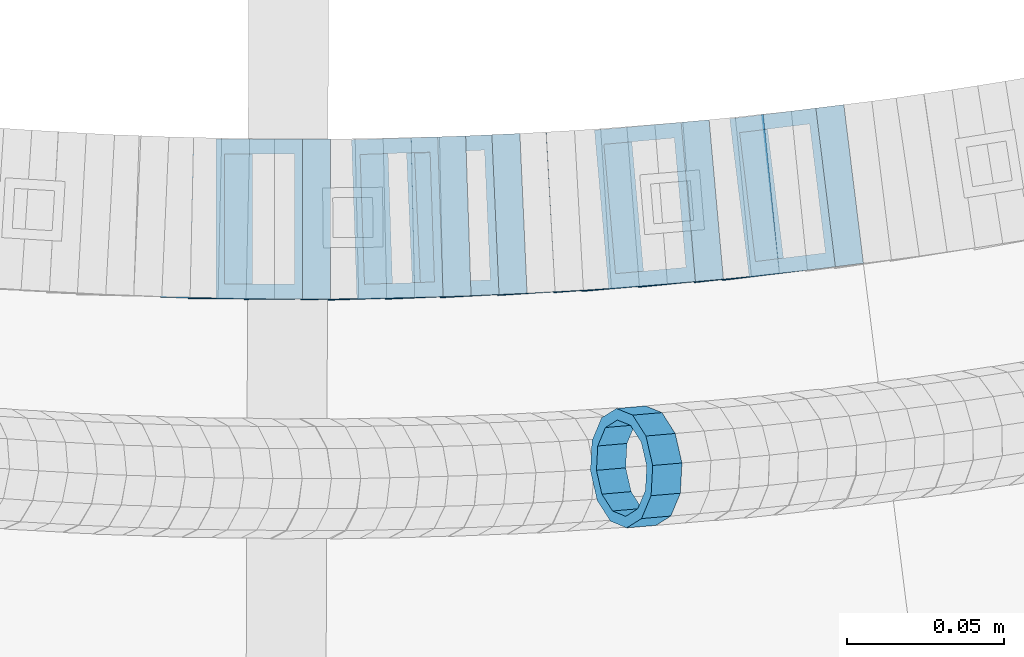
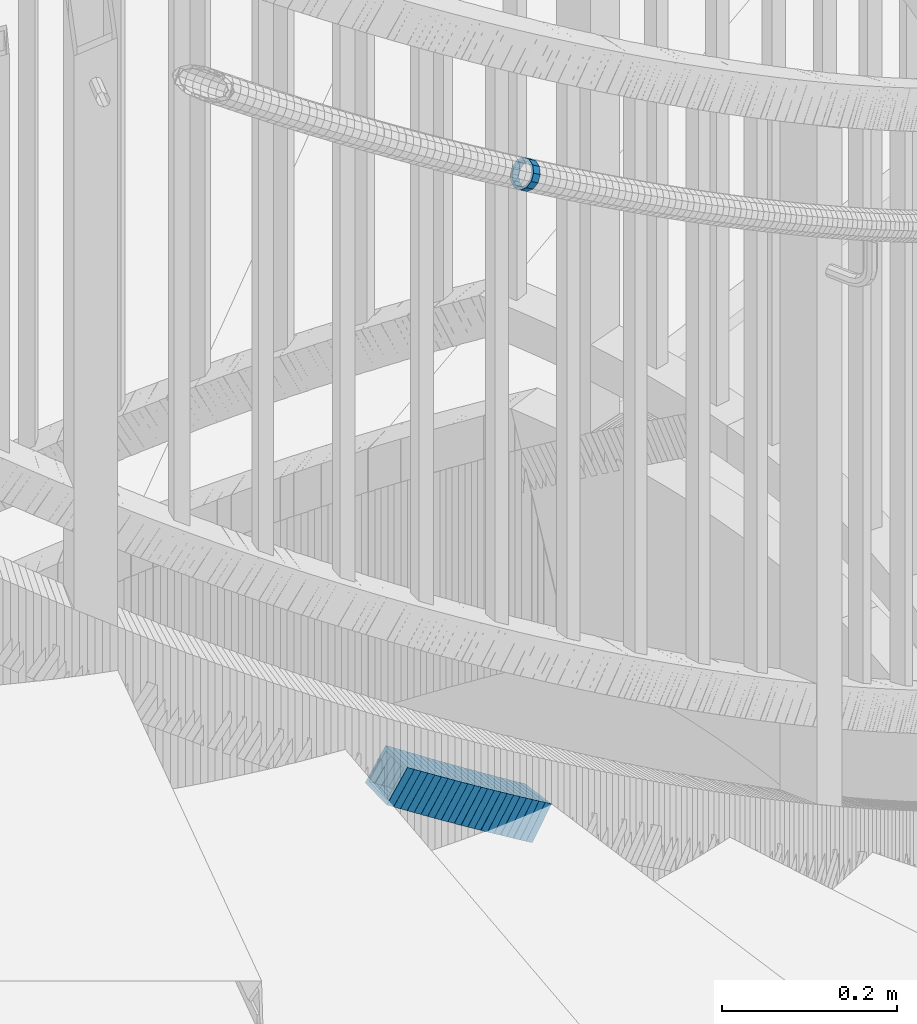
# One storey, part 710 of 975: 23 members.
"""IFC2X3 building model written with IfcOpenShell, lengths in millimetres."""

import ifcopenshell
import ifcopenshell.guid

model = None  # the IFC model being written
_history = None  # IfcOwnerHistory: only IFC2X3 demands one
_inside = {}  # id of a spatial element -> (the spatial element, [elements in it])
_under = {}  # id of a project, library or spatial element -> (it, [spatial elements below it])
_declared = {}  # id of a project -> (the project, [libraries it declares])
_typed = {}  # id of a type object -> (the type object, [elements of that type])
_made_of = {}  # id of a material, layer set ... -> (it, [elements and type objects made of it])


def new_model(schema):
    """Start an empty IFC model of exactly this schema.

    Asked for "IFC4X3", IfcOpenShell would pick the latest addendum, in which some entities
    have other attributes; the version numbers below select the first issue.
    IFC2X3 requires an IfcOwnerHistory on every rooted entity: one is made here for all.
    """
    global model, _history
    if schema == "IFC4X3":
        model = ifcopenshell.file(schema_version=(4, 3, 0, 0))
    else:
        model = ifcopenshell.file(schema=schema)
    _inside.clear()
    _under.clear()
    _declared.clear()
    _typed.clear()
    _made_of.clear()
    _history = None
    if model.schema == "IFC2X3":
        org = make("IfcOrganization", Name="unknown")
        user = make(
            "IfcPersonAndOrganization",
            ThePerson=make("IfcPerson", FamilyName="unknown"),
            TheOrganization=org,
        )
        app = make(
            "IfcApplication",
            ApplicationDeveloper=org,
            Version="unknown",
            ApplicationFullName="unknown",
            ApplicationIdentifier="unknown",
        )
        _history = make(
            "IfcOwnerHistory",
            OwningUser=user,
            OwningApplication=app,
            ChangeAction="ADDED",
            CreationDate=0,
        )
    return model


def make(cls, **values):
    """One entity of the class cls with the attributes given. An attribute that is None is left unset."""
    return model.create_entity(
        cls, **{name: value for name, value in values.items() if value is not None}
    )


def rooted(cls, **values):
    """An entity with a GlobalId (a new one), such as an element, a storey or a relation."""
    return make(cls, GlobalId=ifcopenshell.guid.new(), OwnerHistory=_history, **values)


def si_unit(unit_type, name, prefix=None):
    """IfcSIUnit, for example si_unit("LENGTHUNIT", "METRE", prefix="MILLI")."""
    return make("IfcSIUnit", UnitType=unit_type, Prefix=prefix, Name=name)


def assignment(units):
    """IfcUnitAssignment: the units of a project."""
    return None if units is None else make("IfcUnitAssignment", Units=units)


def point(xyz):
    """IfcCartesianPoint."""
    return None if xyz is None else make("IfcCartesianPoint", Coordinates=xyz)


def direction(xyz):
    """IfcDirection."""
    return None if xyz is None else make("IfcDirection", DirectionRatios=xyz)


def frame(location, z_axis=None, x_axis=None):
    """IfcAxis2Placement3D, a coordinate frame: its origin and axes. An axis left out is left unset."""
    return make(
        "IfcAxis2Placement3D",
        Location=point(location),
        Axis=direction(z_axis),
        RefDirection=direction(x_axis),
    )


def origin_with_axes():
    """The frame at (0, 0, 0) with the z axis (0, 0, 1) and the x axis (1, 0, 0) written out."""
    return frame((0.0, 0.0, 0.0), z_axis=(0.0, 0.0, 1.0), x_axis=(1.0, 0.0, 0.0))


def place(relative_to, where):
    """IfcLocalPlacement: puts the frame where relative to a parent placement (None: the world)."""
    return make(
        "IfcLocalPlacement", PlacementRelTo=relative_to, RelativePlacement=where
    )


def context(
    kind, dimensions, precision=None, world=None, true_north=None, identifier=None
):
    """IfcGeometricRepresentationContext, for example the 3D "Model" context."""
    return make(
        "IfcGeometricRepresentationContext",
        ContextIdentifier=identifier,
        ContextType=kind,
        CoordinateSpaceDimension=dimensions,
        Precision=precision,
        WorldCoordinateSystem=world,
        TrueNorth=true_north,
    )


def subcontext(parent, identifier, kind, view, scale=None):
    """IfcGeometricRepresentationSubContext, for example "Body" below "Model"."""
    return make(
        "IfcGeometricRepresentationSubContext",
        ContextIdentifier=identifier,
        ContextType=kind,
        ParentContext=parent,
        TargetScale=scale,
        TargetView=view,
    )


def project(units=None, contexts=None):
    """IfcProject with its units and contexts."""
    return rooted(
        "IfcProject",
        Name="project",
        RepresentationContexts=contexts,
        UnitsInContext=assignment(units),
    )


def spatial(cls, under=None, at=None, **own):
    """A site, building, storey or space (cls), placed at a placement, below another one or the project."""
    s = rooted(cls, ObjectPlacement=at, **own)
    if under is not None:
        _under.setdefault(under.id(), (under, []))[1].append(s)
    return s


def faces_of(points, faces, orient=None, outer=None):
    """IfcFace entities. A face is a list of loops; a loop is a list of indices into points, from 0.

    orient and outer hold one flag for each loop. By default every Orientation is true, the
    first loop of a face is its IfcFaceOuterBound and the others are IfcFaceBound.
    """
    made = []
    for i, loops in enumerate(faces):
        bounds = []
        for j, loop in enumerate(loops):
            is_outer = j == 0 if outer is None else outer[i][j]
            bounds.append(
                make(
                    "IfcFaceOuterBound" if is_outer else "IfcFaceBound",
                    Bound=make("IfcPolyLoop", Polygon=[points[k] for k in loop]),
                    Orientation=True if orient is None else orient[i][j],
                )
            )
        made.append(make("IfcFace", Bounds=bounds))
    return made


def faceted_brep(points, faces, orient=None, outer=None, voids=None):
    """IfcFacetedBrep: a solid bounded by flat faces; with voids (closed shells), ...WithVoids."""
    shared = [point(p) for p in points]
    hull = make("IfcClosedShell", CfsFaces=faces_of(shared, faces, orient, outer))
    if voids is None:
        return make("IfcFacetedBrep", Outer=hull)
    return make(
        "IfcFacetedBrepWithVoids",
        Outer=hull,
        Voids=[
            make(cls, CfsFaces=faces_of(shared, fs, o, b)) for cls, fs, o, b in voids
        ],
    )


def shape(context_of_items, identifier, shape_type, items):
    """IfcShapeRepresentation: the items that make up one representation, for example the "Body"."""
    return make(
        "IfcShapeRepresentation",
        ContextOfItems=context_of_items,
        RepresentationIdentifier=identifier,
        RepresentationType=shape_type,
        Items=items,
    )


def material(Name=None, Category=None):
    """IfcMaterial."""
    return make("IfcMaterial", Name=Name, Category=Category)


def made_of(thing, what):
    """Note that an element or type object is made of a material, layer set ...; save() writes the relation."""
    if what is not None:
        _made_of.setdefault(what.id(), (what, []))[1].append(thing)
    return thing


def type_object(cls, material=None, **own):
    """A type object (cls), such as IfcWallType, which elements share."""
    return made_of(rooted(cls, **own), material)


def element(
    cls,
    number,
    at=None,
    inside=None,
    cuts=None,
    type_object=None,
    material=None,
    context=None,
    identifier="Body",
    shape_type=None,
    held_by="IfcProductDefinitionShape",
    body=None,
    shapes=None,
    **own,
):
    """One element of the class cls, such as IfcWall. Its Tag is "e" and its number.

    at: its placement. inside: the storey or other place that contains it. cuts: it is an
    opening in that element (IfcRelVoidsElement). A single representation is given by context,
    identifier, shape_type and body (its items); several are given by shapes. held_by: the class
    of the entity that holds the representations. save() writes the other relations.
    """
    e = rooted(cls, Tag="e%d" % number, ObjectPlacement=at, **own)
    if body is not None:
        shapes = [shape(context, identifier, shape_type, body)]
    if shapes is not None:
        e.Representation = make(held_by, Representations=shapes)
    if inside is not None:
        _inside.setdefault(inside.id(), (inside, []))[1].append(e)
    if cuts is not None:
        rooted(
            "IfcRelVoidsElement", RelatingBuildingElement=cuts, RelatedOpeningElement=e
        )
    if type_object is not None:
        _typed.setdefault(type_object.id(), (type_object, []))[1].append(e)
    return made_of(e, material)


def aggregate(whole, parts):
    """IfcRelAggregates: a whole, such as a stair, and the parts it consists of."""
    return rooted("IfcRelAggregates", RelatingObject=whole, RelatedObjects=parts)


def save(model, path):
    """Write the relations noted so far, then the file.

    IfcRelAggregates (storeys below a building ...), IfcRelContainedInSpatialStructure (elements
    in a storey), IfcRelDefinesByType, IfcRelAssociatesMaterial and IfcRelDeclares: one each for
    every whole, place, type object, material and project.
    """
    for whole, parts in _under.values():
        aggregate(whole, parts)
    for where, things in _inside.values():
        rooted(
            "IfcRelContainedInSpatialStructure",
            RelatedElements=things,
            RelatingStructure=where,
        )
    for kind, things in _typed.values():
        rooted("IfcRelDefinesByType", RelatedObjects=things, RelatingType=kind)
    for what, things in _made_of.values():
        rooted("IfcRelAssociatesMaterial", RelatedObjects=things, RelatingMaterial=what)
    for by, libraries in _declared.values():
        rooted("IfcRelDeclares", RelatingContext=by, RelatedDefinitions=libraries)
    model.write(path)


model = new_model("IFC2X3")

# Units and contexts
model_context = context("Model", 3, precision=1e-05, world=origin_with_axes())
body_context = subcontext(model_context, "Body", "Model", "MODEL_VIEW")
ifc_project = project(units=[si_unit("LENGTHUNIT", "METRE", prefix="MILLI"), si_unit("AREAUNIT", "SQUARE_METRE"), si_unit("VOLUMEUNIT", "CUBIC_METRE"), si_unit("MASSUNIT", "GRAM", prefix="KILO"), si_unit("TIMEUNIT", "SECOND"), si_unit("PLANEANGLEUNIT", "RADIAN"), si_unit("SOLIDANGLEUNIT", "STERADIAN"), si_unit("THERMODYNAMICTEMPERATUREUNIT", "DEGREE_CELSIUS"), si_unit("LUMINOUSINTENSITYUNIT", "LUMEN")], contexts=[model_context])

# Site, building, storey
site_placement = place(None, origin_with_axes())
site = spatial("IfcSite", under=ifc_project, at=site_placement, CompositionType="ELEMENT")
building_placement = place(site_placement, origin_with_axes())
building = spatial("IfcBuilding", under=site, at=building_placement, Name="Undefined", CompositionType="ELEMENT")
storey_placement = place(building_placement, origin_with_axes())
storey = spatial("IfcBuildingStorey", under=building, at=storey_placement, Name="Undefined", CompositionType="ELEMENT", Elevation=0.0)

# Members
ifc_material = material()
member_type_1 = type_object("IfcMemberType", PredefinedType="NOTDEFINED")
member_1_placement = place(storey_placement, frame((34845.1050028849, 1928.05650015776, 4138.74163248129), z_axis=(0.0857049938306082, -0.99632055786905, 9.78916432359256e-11), x_axis=(-0.850317367145027, -0.07314558001246, 0.521162258088774)))
element("IfcMember", 1, at=member_1_placement, inside=storey, type_object=member_type_1, material=ifc_material, Name="WALL", context=body_context, shape_type="Brep", body=[
    faceted_brep([(-2.1246523829177e-07, -15.367000000002, 0.0), (-1.83998054126278e-07, -13.3082123799541, 7.68350000000009), (10.9448618081915, -13.3082123799541, 7.68349999999987), (10.944861808206, -15.3669999999875, -1.81898940354586e-12), (-1.06232619145885e-07, -7.68349999999919, 13.3082123799559), (10.9448618081733, -7.68350000000282, 13.3082123799568), (-3.63797880709171e-12, 3.63797880709171e-12, 15.3670000000002), (10.944861808166, -1.09139364212751e-11, 15.3670000000025), (1.06225343188271e-07, 7.68350000000646, 13.3082123799559), (10.9448618081624, 7.68349999998827, 13.3082123799586), (1.8399441614747e-07, 13.308212379965, 7.68350000000009), (10.9448618081697, 13.3082123799468, 7.68350000000214), (2.12461600312963e-07, 15.3670000000093, 0.0), (10.9448618081842, 15.3669999999984, 2.27373675443232e-13), (1.8399441614747e-07, 13.308212379965, -7.68350000000009), (10.9448618082024, 13.3082123799613, -7.68350000000123), (1.06225343188271e-07, 7.68350000000646, -13.3082123799559), (10.944861808217, 7.68350000001374, -13.3082123799586), (-3.63797880709171e-12, 3.63797880709171e-12, -15.3670000000002), (10.9448618082242, 1.45519152283669e-11, -15.3670000000036), (-1.06232619145885e-07, -7.68349999999919, -13.3082123799559), (10.9448618082279, -7.68349999997736, -13.30821237996), (-1.83998054126278e-07, -13.3082123799541, -7.68350000000009), (10.9448618082242, -13.3082123799322, -7.68350000000351), (-2.63386027654633e-07, -19.0500000000029, 0.0), (-2.28097633225843e-07, -16.4977839420972, -9.52499999999964), (10.9448618082242, -16.4977839420681, -9.52500000000418), (10.9448618082097, -19.0499999999847, -2.50111042987555e-12), (-1.31691194837913e-07, -9.52500000000146, -16.4977839420935), (10.9448618082351, -9.52499999997599, -16.4977839420985), (-3.63797880709171e-12, 3.63797880709171e-12, -19.0500000000002), (10.9448618082315, 2.5465851649642e-11, -19.050000000004), (1.31687556859106e-07, 9.52500000000509, -16.4977839420935), (10.9448618082242, 9.52500000001601, -16.4977839420967), (2.28097633225843e-07, 16.4977839421044, -9.52499999999964), (10.9448618082097, 16.4977839421008, -9.52500000000146), (2.63382389675826e-07, 19.0500000000138, 0.0), (10.9448618081842, 19.049999999992, 1.13686837721616e-12), (2.28097633225843e-07, 16.4977839421044, 9.52499999999964), (10.944861808166, 16.4977839420826, 9.52500000000259), (1.31687556859106e-07, 9.52500000000509, 16.4977839420935), (10.9448618081624, 9.52499999998327, 16.4977839420972), (-3.63797880709171e-12, 3.63797880709171e-12, 19.0500000000002), (10.9448618081587, -1.09139364212751e-11, 19.0500000000031), (-1.31691194837913e-07, -9.52500000000146, 16.4977839420935), (10.9448618081697, -9.52500000000873, 16.4977839420953), (-2.28097633225843e-07, -16.4977839420972, 9.52499999999964), (10.9448618081915, -16.4977839420899, 9.52499999999941)], [[[0, 1, 2, 3]], [[1, 4, 5, 2]], [[4, 6, 7, 5]], [[6, 8, 9, 7]], [[8, 10, 11, 9]], [[10, 12, 13, 11]], [[12, 14, 15, 13]], [[14, 16, 17, 15]], [[16, 18, 19, 17]], [[18, 20, 21, 19]], [[20, 22, 23, 21]], [[22, 0, 3, 23]], [[24, 25, 26, 27]], [[25, 28, 29, 26]], [[28, 30, 31, 29]], [[30, 32, 33, 31]], [[32, 34, 35, 33]], [[34, 36, 37, 35]], [[36, 38, 39, 37]], [[38, 40, 41, 39]], [[40, 42, 43, 41]], [[42, 44, 45, 43]], [[44, 46, 47, 45]], [[46, 24, 27, 47]], [[29, 31, 33, 35, 37, 39, 41, 43, 45, 47, 27, 26], [5, 7, 9, 11, 13, 15, 17, 19, 21, 23, 3, 2]], [[46, 44, 42, 40, 38, 36, 34, 32, 30, 28, 25, 24], [22, 20, 18, 16, 14, 12, 10, 8, 6, 4, 1, 0]]]),
])
member_type_2 = type_object("IfcMemberType", Name="HSS2X2X.188_TUBES", PredefinedType="NOTDEFINED")
member_2_placement = place(storey_placement, frame((34712.1585496594, 2006.62334956204, 3299.34121631951), z_axis=(-0.0111104251425932, -0.999938277321731, 8.80345396581106e-11), x_axis=(-0.844781858065906, 0.00938646500072175, 0.535028510041759)))
element("IfcMember", 2, at=member_2_placement, inside=storey, type_object=member_type_2, material=ifc_material, Name="WALL", ObjectType="HSS2X2X.188_TUBES", context=body_context, shape_type="Brep", body=[
    faceted_brep([(0.0, 20.6374999999753, -20.6375000000298), (0.0, -20.6375000000153, -20.6375000000153), (10.648004507897, -20.6374999999862, -20.637499999968), (10.6480045078188, 20.6374999999771, -20.6375000000808), (0.0, -20.6374999999825, 20.6375000000335), (10.6480045079406, -20.6374999999698, 20.6375000001062), (0.0, 20.6375000000116, 20.6375000000189), (10.6480045078679, 20.6374999999935, 20.6375000000007), (0.0, 25.3999999999724, -25.4000000000342), (0.0, 25.400000000016, 25.4000000000196), (10.6480045078661, 25.3999999999905, 25.4000000000015), (10.648004507806, 25.3999999999705, -25.4000000000997), (0.0, -25.399999999976, 25.4000000000378), (10.6480045079552, -25.3999999999633, 25.4000000001288), (0.0, -25.400000000016, -25.4000000000196), (10.6480045078988, -25.3999999999814, -25.3999999999651)], [[[0, 1, 2, 3]], [[1, 4, 5, 2]], [[4, 6, 7, 5]], [[6, 0, 3, 7]], [[8, 9, 10, 11]], [[9, 12, 13, 10]], [[12, 14, 15, 13]], [[14, 8, 11, 15]], [[13, 15, 11, 10], [5, 7, 3, 2]], [[14, 12, 9, 8], [6, 4, 1, 0]]]),
])
for number, where, z_axis, x_axis, name in (
    (3, (34720.6664472317, 2006.47392970298, 3293.71067218533), (0.0, -1.0, 0.0), (-0.842099520608961, 0.0, 0.539322164749567), "WALL"),
    (4, (34729.5664472317, 2006.47392970298, 3288.01067218534), (0.0, -1.0, 0.0), (-0.842099520608961, 0.0, 0.539322164749567), "WALL"),
):
    element("IfcMember", number, at=place(storey_placement, frame(where, z_axis=z_axis, x_axis=x_axis)), inside=storey, type_object=member_type_2, material=ifc_material, Name=name, ObjectType="HSS2X2X.188_TUBES", context=body_context, shape_type="Brep", body=[
        faceted_brep([(0.0, 20.6374999999753, -20.6375000000298), (0.0, -20.6375000000153, -20.6375000000153), (10.5744976239494, -20.6375000000207, -20.6375000000335), (10.5744976239657, 20.6375000000098, -20.637500000008), (0.0, -20.6374999999825, 20.6375000000335), (10.5744976239639, -20.6375000000244, 20.6374999999753), (0.0, 20.6375000000116, 20.6375000000189), (10.5744976239803, 20.6374999999989, 20.6374999999935), (0.0, 25.3999999999724, -25.4000000000342), (0.0, 25.400000000016, 25.4000000000196), (10.5744976239857, 25.4000000000051, 25.4000000000015), (10.5744976239675, 25.4000000000124, -25.4000000000051), (0.0, -25.399999999976, 25.4000000000378), (10.5744976239639, -25.4000000000287, 25.3999999999724), (0.0, -25.400000000016, -25.4000000000196), (10.5744976239494, -25.4000000000215, -25.4000000000378)], [[[0, 1, 2, 3]], [[1, 4, 5, 2]], [[4, 6, 7, 5]], [[6, 0, 3, 7]], [[8, 9, 10, 11]], [[9, 12, 13, 10]], [[12, 14, 15, 13]], [[14, 8, 11, 15]], [[13, 15, 11, 10], [5, 7, 3, 2]], [[14, 12, 9, 8], [6, 4, 1, 0]]]),
    ])
member_3_placement = place(storey_placement, frame((34738.2252608239, 2006.41949789588, 3282.24910901859), z_axis=(0.0111104253462836, -0.999938277319468, -2.20848505705362e-10), x_axis=(-0.840534376147921, -0.00933927100164839, 0.541677709095346)))
element("IfcMember", 5, at=member_3_placement, inside=storey, type_object=member_type_2, material=ifc_material, Name="WALL", ObjectType="HSS2X2X.188_TUBES", context=body_context, shape_type="Brep", body=[
    faceted_brep([(0.0, 20.6374999999753, -20.6375000000298), (0.0, -20.6375000000153, -20.6375000000153), (10.7093417165161, -20.637499999968, -20.6374999999534), (10.709341716436, 20.6374999999898, -20.6375000000116), (0.0, -20.6374999999825, 20.6375000000335), (10.7093417164688, -20.6374999999971, 20.6375000000153), (0.0, 20.6375000000116, 20.6375000000189), (10.7093417163924, 20.6374999999643, 20.6374999999571), (0.0, 25.3999999999724, -25.4000000000342), (0.0, 25.400000000016, 25.4000000000196), (10.7093417163815, 25.3999999999542, 25.3999999999469), (10.7093417164288, 25.3999999999869, -25.4000000000196), (0.0, -25.399999999976, 25.4000000000378), (10.7093417164724, -25.3999999999942, 25.4000000000196), (0.0, -25.400000000016, -25.4000000000196), (10.709341716527, -25.3999999999578, -25.3999999999432)], [[[0, 1, 2, 3]], [[1, 4, 5, 2]], [[4, 6, 7, 5]], [[6, 0, 3, 7]], [[8, 9, 10, 11]], [[9, 12, 13, 10]], [[12, 14, 15, 13]], [[14, 8, 11, 15]], [[13, 15, 11, 10], [5, 7, 3, 2]], [[14, 12, 9, 8], [6, 4, 1, 0]]]),
])
for number, where, z_axis, x_axis, name in (
    (6, (34747.1825497331, 2006.51842421579, 3276.51027950351), (0.0112352460312104, -0.999936882631408, -2.26395968638826e-11), (-0.84206182823285, -0.00946136900261019, 0.539298025149125), "WALL"),
    (7, (34755.8017138262, 2006.55981376691, 3270.80910192297), (0.0224662378870489, -0.999747602225283, 7.55430846766103e-11), (-0.841948781990538, -0.0189201969997969, 0.53922562499397), "WALL"),
):
    element("IfcMember", number, at=place(storey_placement, frame(where, z_axis=z_axis, x_axis=x_axis)), inside=storey, type_object=member_type_2, material=ifc_material, Name=name, ObjectType="HSS2X2X.188_TUBES", context=body_context, shape_type="Brep", body=[
        faceted_brep([(0.0, 20.6374999999753, -20.6375000000298), (0.0, -20.6375000000153, -20.6375000000153), (10.5744976239494, -20.6375000000207, -20.6375000000335), (10.5744976239657, 20.6375000000098, -20.637500000008), (0.0, -20.6374999999825, 20.6375000000335), (10.5744976239639, -20.6375000000244, 20.6374999999753), (0.0, 20.6375000000116, 20.6375000000189), (10.5744976239803, 20.6374999999989, 20.6374999999935), (0.0, 25.3999999999724, -25.4000000000342), (0.0, 25.400000000016, 25.4000000000196), (10.5744976239857, 25.4000000000051, 25.4000000000015), (10.5744976239675, 25.4000000000124, -25.4000000000051), (0.0, -25.399999999976, 25.4000000000378), (10.5744976239639, -25.4000000000287, 25.3999999999724), (0.0, -25.400000000016, -25.4000000000196), (10.5744976239494, -25.4000000000215, -25.4000000000378)], [[[0, 1, 2, 3]], [[1, 4, 5, 2]], [[4, 6, 7, 5]], [[6, 0, 3, 7]], [[8, 9, 10, 11]], [[9, 12, 13, 10]], [[12, 14, 15, 13]], [[14, 8, 11, 15]], [[13, 15, 11, 10], [5, 7, 3, 2]], [[14, 12, 9, 8], [6, 4, 1, 0]]]),
    ])
member_4_placement = place(storey_placement, frame((34764.472852071, 2006.70162429159, 3265.04601811882), z_axis=(0.0333148305282084, -0.999444906969302, -3.40677615895402e-10), x_axis=(-0.840241277217946, -0.0280080430072683, 0.541488823140477)))
element("IfcMember", 8, at=member_4_placement, inside=storey, type_object=member_type_2, material=ifc_material, Name="WALL", ObjectType="HSS2X2X.188_TUBES", context=body_context, shape_type="Brep", body=[
    faceted_brep([(0.0, 20.6374999999753, -20.6375000000298), (0.0, -20.6375000000153, -20.6375000000153), (10.7093417165161, -20.637499999968, -20.6374999999534), (10.709341716436, 20.6374999999898, -20.6375000000116), (0.0, -20.6374999999825, 20.6375000000335), (10.7093417164688, -20.6374999999971, 20.6375000000153), (0.0, 20.6375000000116, 20.6375000000189), (10.7093417163924, 20.6374999999643, 20.6374999999571), (0.0, 25.3999999999724, -25.4000000000342), (0.0, 25.400000000016, 25.4000000000196), (10.7093417163815, 25.3999999999542, 25.3999999999469), (10.7093417164288, 25.3999999999869, -25.4000000000196), (0.0, -25.399999999976, 25.4000000000378), (10.7093417164724, -25.3999999999942, 25.4000000000196), (0.0, -25.400000000016, -25.4000000000196), (10.709341716527, -25.3999999999578, -25.3999999999432)], [[[0, 1, 2, 3]], [[1, 4, 5, 2]], [[4, 6, 7, 5]], [[6, 0, 3, 7]], [[8, 9, 10, 11]], [[9, 12, 13, 10]], [[12, 14, 15, 13]], [[14, 8, 11, 15]], [[13, 15, 11, 10], [5, 7, 3, 2]], [[14, 12, 9, 8], [6, 4, 1, 0]]]),
])
member_5_placement = place(storey_placement, frame((34773.4240415321, 2006.99820317496, 3259.30714083712), z_axis=(0.0336887321754766, -0.999432373562318, -1.21692210086621e-10), x_axis=(-0.841760473154611, -0.0283739490052088, 0.539105022099011)))
element("IfcMember", 9, at=member_5_placement, inside=storey, type_object=member_type_2, material=ifc_material, Name="WALL", ObjectType="HSS2X2X.188_TUBES", context=body_context, shape_type="Brep", body=[
    faceted_brep([(0.0, 20.6374999999753, -20.6375000000298), (0.0, -20.6375000000153, -20.6375000000153), (10.5744976239494, -20.6375000000207, -20.6375000000335), (10.5744976239657, 20.6375000000098, -20.637500000008), (0.0, -20.6374999999825, 20.6375000000335), (10.5744976239639, -20.6375000000244, 20.6374999999753), (0.0, 20.6375000000116, 20.6375000000189), (10.5744976239803, 20.6374999999989, 20.6374999999935), (0.0, 25.3999999999724, -25.4000000000342), (0.0, 25.400000000016, 25.4000000000196), (10.5744976239857, 25.4000000000051, 25.4000000000015), (10.5744976239675, 25.4000000000124, -25.4000000000051), (0.0, -25.399999999976, 25.4000000000378), (10.5744976239639, -25.4000000000287, 25.3999999999724), (0.0, -25.400000000016, -25.4000000000196), (10.5744976239494, -25.4000000000215, -25.4000000000378)], [[[0, 1, 2, 3]], [[1, 4, 5, 2]], [[4, 6, 7, 5]], [[6, 0, 3, 7]], [[8, 9, 10, 11]], [[9, 12, 13, 10]], [[12, 14, 15, 13]], [[14, 8, 11, 15]], [[13, 15, 11, 10], [5, 7, 3, 2]], [[14, 12, 9, 8], [6, 4, 1, 0]]]),
])
for number, where, z_axis, x_axis, name in (
    (10, (34782.0496306093, 2007.23370044269, 3253.60439856372), (0.044898496675909, -0.998991554016471, 2.07617631531321e-10), (-0.841497052206438, -0.0378200920092716, 0.538936315132211), "WALL"),
    (11, (34790.9496306093, 2007.63370044269, 3247.90439856373), (0.044898496675909, -0.998991554016471, 2.07617631531321e-10), (-0.841497052206438, -0.0378200920092716, 0.538936315132211), "WALL"),
):
    element("IfcMember", number, at=place(storey_placement, frame(where, z_axis=z_axis, x_axis=x_axis)), inside=storey, type_object=member_type_2, material=ifc_material, Name=name, ObjectType="HSS2X2X.188_TUBES", context=body_context, shape_type="Brep", body=[
        faceted_brep([(0.0, 20.6374999999753, -20.6375000000298), (0.0, -20.6375000000153, -20.6375000000153), (10.5806427026419, -20.6374999999607, -20.6374999999316), (10.5806427026473, 20.6375000000444, -20.6374999999207), (0.0, -20.6374999999825, 20.6375000000335), (10.5806427025509, -20.6375000000207, 20.6374999999643), (0.0, 20.6375000000116, 20.6375000000189), (10.5806427025545, 20.6374999999862, 20.6374999999716), (0.0, 25.3999999999724, -25.4000000000342), (0.0, 25.400000000016, 25.4000000000196), (10.5806427025436, 25.3999999999796, 25.3999999999614), (10.5806427026582, 25.4000000000542, -25.3999999999105), (0.0, -25.399999999976, 25.4000000000378), (10.5806427025418, -25.4000000000287, 25.3999999999542), (0.0, -25.400000000016, -25.4000000000196), (10.5806427026528, -25.3999999999542, -25.3999999999178)], [[[0, 1, 2, 3]], [[1, 4, 5, 2]], [[4, 6, 7, 5]], [[6, 0, 3, 7]], [[8, 9, 10, 11]], [[9, 12, 13, 10]], [[12, 14, 15, 13]], [[14, 8, 11, 15]], [[13, 15, 11, 10], [5, 7, 3, 2]], [[14, 12, 9, 8], [6, 4, 1, 0]]]),
    ])
member_6_placement = place(storey_placement, frame((34799.4097476553, 2007.95693186597, 3242.20994936357), z_axis=(0.0560913282914407, -0.998425642143921, -1.84075361175928e-10), x_axis=(-0.836871357702261, -0.047015244983266, 0.545376839805961)))
element("IfcMember", 12, at=member_6_placement, inside=storey, type_object=member_type_2, material=ifc_material, Name="WALL", ObjectType="HSS2X2X.188_TUBES", context=body_context, shape_type="Brep", body=[
    faceted_brep([(0.0, 20.6374999999753, -20.6375000000298), (0.0, -20.6375000000153, -20.6375000000153), (10.6348483769107, -20.637499999988, -20.6374999999825), (10.6348483768415, 20.6374999999734, -20.6375000001026), (0.0, -20.6374999999825, 20.6375000000335), (10.6348483769852, -20.6374999999589, 20.6375000001462), (0.0, 20.6375000000116, 20.6375000000189), (10.6348483769161, 20.6375000000044, 20.6375000000226), (0.0, 25.3999999999724, -25.4000000000342), (0.0, 25.400000000016, 25.4000000000196), (10.6348483769179, 25.4000000000015, 25.4000000000233), (10.6348483768288, 25.3999999999669, -25.4000000001324), (0.0, -25.399999999976, 25.4000000000378), (10.6348483769998, -25.3999999999505, 25.4000000001688), (0.0, -25.400000000016, -25.4000000000196), (10.6348483769107, -25.3999999999887, -25.3999999999833)], [[[0, 1, 2, 3]], [[1, 4, 5, 2]], [[4, 6, 7, 5]], [[6, 0, 3, 7]], [[8, 9, 10, 11]], [[9, 12, 13, 10]], [[12, 14, 15, 13]], [[14, 8, 11, 15]], [[13, 15, 11, 10], [5, 7, 3, 2]], [[14, 12, 9, 8], [6, 4, 1, 0]]]),
])
member_7_placement = place(storey_placement, frame((34808.7018140968, 2008.48179613976, 3236.33213827413), z_axis=(0.0554700197800703, -0.99846035319666, 1.45757894642884e-10), x_axis=(-0.843890110558141, -0.0468827839754443, 0.534463736720164)))
element("IfcMember", 13, at=member_7_placement, inside=storey, type_object=member_type_2, material=ifc_material, Name="WALL", ObjectType="HSS2X2X.188_TUBES", context=body_context, shape_type="Brep", body=[
    faceted_brep([(0.0, 20.6374999999753, -20.6375000000298), (0.0, -20.6375000000153, -20.6375000000153), (10.6625512894789, -20.6374999999625, -20.6374999999389), (10.6625512893879, 20.6374999999789, -20.6375000000371), (0.0, -20.6374999999825, 20.6375000000335), (10.6625512894352, -20.6374999999989, 20.6375000000153), (0.0, 20.6375000000116, 20.6375000000189), (10.6625512893443, 20.6374999999443, 20.6374999999134), (0.0, 25.3999999999724, -25.4000000000342), (0.0, 25.400000000016, 25.4000000000196), (10.6625512893297, 25.3999999999342, 25.3999999998996), (10.6625512893916, 25.399999999976, -25.4000000000415), (0.0, -25.399999999976, 25.4000000000378), (10.6625512894389, -25.399999999996, 25.400000000016), (0.0, -25.400000000016, -25.4000000000196), (10.6625512894971, -25.3999999999523, -25.3999999999214)], [[[0, 1, 2, 3]], [[1, 4, 5, 2]], [[4, 6, 7, 5]], [[6, 0, 3, 7]], [[8, 9, 10, 11]], [[9, 12, 13, 10]], [[12, 14, 15, 13]], [[14, 8, 11, 15]], [[13, 15, 11, 10], [5, 7, 3, 2]], [[14, 12, 9, 8], [6, 4, 1, 0]]]),
])
member_8_placement = place(storey_placement, frame((34817.2109616, 2008.89646502111, 3230.69658430275), z_axis=(0.0672630522607651, -0.997735276413822, -1.4846455087536e-10), x_axis=(-0.840745783012367, -0.0566794910008438, 0.538455164007931)))
element("IfcMember", 14, at=member_8_placement, inside=storey, type_object=member_type_2, material=ifc_material, Name="WALL", ObjectType="HSS2X2X.188_TUBES", context=body_context, shape_type="Brep", body=[
    faceted_brep([(0.0, 20.6374999999753, -20.6375000000298), (0.0, -20.6375000000153, -20.6375000000153), (10.5948100501191, -20.6375000000335, -20.6375000000844), (10.5948100501555, 20.6374999999971, -20.6375000000116), (0.0, -20.6374999999825, 20.6375000000335), (10.5948100501446, -20.6375000000098, 20.6374999999571), (0.0, 20.6375000000116, 20.6375000000189), (10.5948100501828, 20.6375000000189, 20.6375000000298), (0.0, 25.3999999999724, -25.4000000000342), (0.0, 25.400000000016, 25.4000000000196), (10.5948100501919, 25.4000000000251, 25.4000000000451), (10.5948100501591, 25.3999999999978, -25.4000000000051), (0.0, -25.399999999976, 25.4000000000378), (10.5948100501482, -25.4000000000106, 25.3999999999578), (0.0, -25.400000000016, -25.4000000000196), (10.5948100501118, -25.4000000000378, -25.400000000096)], [[[0, 1, 2, 3]], [[1, 4, 5, 2]], [[4, 6, 7, 5]], [[6, 0, 3, 7]], [[8, 9, 10, 11]], [[9, 12, 13, 10]], [[12, 14, 15, 13]], [[14, 8, 11, 15]], [[13, 15, 11, 10], [5, 7, 3, 2]], [[14, 12, 9, 8], [6, 4, 1, 0]]]),
])
member_9_placement = place(storey_placement, frame((34825.9422654891, 2009.48509224958, 3225.00557094411), z_axis=(0.0672630522607651, -0.997735276413822, -1.4846455087536e-10), x_axis=(-0.836464687746532, -0.0563908779829033, 0.545111818834828)))
element("IfcMember", 15, at=member_9_placement, inside=storey, type_object=member_type_2, material=ifc_material, Name="WALL", ObjectType="HSS2X2X.188_TUBES", context=body_context, shape_type="Brep", body=[
    faceted_brep([(0.0, 20.6374999999753, -20.6375000000298), (0.0, -20.6375000000153, -20.6375000000153), (10.6395488625676, -20.6374999999771, -20.6374999999716), (10.6395488625531, 20.6374999999916, -20.6375000000189), (0.0, -20.6374999999825, 20.6375000000335), (10.6395488625731, -20.6374999999844, 20.6375000000153), (0.0, 20.6375000000116, 20.6375000000189), (10.6395488625585, 20.6374999999825, 20.637499999968), (0.0, 25.3999999999724, -25.4000000000342), (0.0, 25.400000000016, 25.4000000000196), (10.6395488625567, 25.3999999999778, 25.3999999999614), (10.6395488625494, 25.3999999999887, -25.4000000000233), (0.0, -25.399999999976, 25.4000000000378), (10.6395488625749, -25.3999999999851, 25.400000000016), (0.0, -25.400000000016, -25.4000000000196), (10.6395488625658, -25.399999999976, -25.3999999999687)], [[[0, 1, 2, 3]], [[1, 4, 5, 2]], [[4, 6, 7, 5]], [[6, 0, 3, 7]], [[8, 9, 10, 11]], [[9, 12, 13, 10]], [[12, 14, 15, 13]], [[14, 8, 11, 15]], [[13, 15, 11, 10], [5, 7, 3, 2]], [[14, 12, 9, 8], [6, 4, 1, 0]]]),
])
member_10_placement = place(storey_placement, frame((34834.7468762706, 2010.02396202908, 3219.19152149674), z_axis=(0.0784095351745709, -0.996921232993714, -1.11433109850623e-10), x_axis=(-0.840258535020135, -0.0660877500015877, 0.538143107012944)))
element("IfcMember", 16, at=member_10_placement, inside=storey, type_object=member_type_2, material=ifc_material, Name="WALL", ObjectType="HSS2X2X.188_TUBES", context=body_context, shape_type="Brep", body=[
    faceted_brep([(0.0, 20.6374999999753, -20.6375000000298), (0.0, -20.6375000000153, -20.6375000000153), (10.5948100501191, -20.6375000000335, -20.6375000000844), (10.5948100501555, 20.6374999999971, -20.6375000000116), (0.0, -20.6374999999825, 20.6375000000335), (10.5948100501446, -20.6375000000098, 20.6374999999571), (0.0, 20.6375000000116, 20.6375000000189), (10.5948100501828, 20.6375000000189, 20.6375000000298), (0.0, 25.3999999999724, -25.4000000000342), (0.0, 25.400000000016, 25.4000000000196), (10.5948100501919, 25.4000000000251, 25.4000000000451), (10.5948100501591, 25.3999999999978, -25.4000000000051), (0.0, -25.399999999976, 25.4000000000378), (10.5948100501482, -25.4000000000106, 25.3999999999578), (0.0, -25.400000000016, -25.4000000000196), (10.5948100501118, -25.4000000000378, -25.400000000096)], [[[0, 1, 2, 3]], [[1, 4, 5, 2]], [[4, 6, 7, 5]], [[6, 0, 3, 7]], [[8, 9, 10, 11]], [[9, 12, 13, 10]], [[12, 14, 15, 13]], [[14, 8, 11, 15]], [[13, 15, 11, 10], [5, 7, 3, 2]], [[14, 12, 9, 8], [6, 4, 1, 0]]]),
])
member_11_placement = place(storey_placement, frame((34843.3863975658, 2010.64902576884, 3213.4856958392), z_axis=(0.0895266898351547, -0.995984423476171, 1.31919478008058e-10), x_axis=(-0.839697377603004, -0.0754784159643172, 0.537783713745736)))
element("IfcMember", 17, at=member_11_placement, inside=storey, type_object=member_type_2, material=ifc_material, Name="WALL", ObjectType="HSS2X2X.188_TUBES", context=body_context, shape_type="Brep", body=[
    faceted_brep([(0.0, 20.6374999999753, -20.6375000000298), (0.0, -20.6375000000153, -20.6375000000153), (10.6004716875832, -20.6375000000153, -20.6375000000553), (10.6004716875814, 20.6374999999898, -20.6375000000444), (0.0, -20.6374999999825, 20.6375000000335), (10.6004716876068, -20.6375000000044, 20.6374999999862), (0.0, 20.6375000000116, 20.6375000000189), (10.6004716876032, 20.6374999999989, 20.6374999999971), (0.0, 25.3999999999724, -25.4000000000342), (0.0, 25.400000000016, 25.4000000000196), (10.600471687605, 25.4000000000015, 25.4000000000051), (10.6004716875814, 25.3999999999869, -25.4000000000487), (0.0, -25.399999999976, 25.4000000000378), (10.6004716876068, -25.4000000000015, 25.3999999999905), (0.0, -25.400000000016, -25.4000000000196), (10.6004716875814, -25.4000000000178, -25.4000000000669)], [[[0, 1, 2, 3]], [[1, 4, 5, 2]], [[4, 6, 7, 5]], [[6, 0, 3, 7]], [[8, 9, 10, 11]], [[9, 12, 13, 10]], [[12, 14, 15, 13]], [[14, 8, 11, 15]], [[13, 15, 11, 10], [5, 7, 3, 2]], [[14, 12, 9, 8], [6, 4, 1, 0]]]),
])
member_12_placement = place(storey_placement, frame((34852.1180331221, 2011.43389188626, 3207.7944682119), z_axis=(0.0895266898351547, -0.995984423476171, 1.31919478008058e-10), x_axis=(-0.835432196861882, -0.0750950289875941, 0.544438959909999)))
element("IfcMember", 18, at=member_12_placement, inside=storey, type_object=member_type_2, material=ifc_material, Name="WALL", ObjectType="HSS2X2X.188_TUBES", context=body_context, shape_type="Brep", body=[
    faceted_brep([(0.0, 20.6374999999753, -20.6375000000298), (0.0, -20.6375000000153, -20.6375000000153), (10.648004507897, -20.6374999999862, -20.637499999968), (10.6480045078188, 20.6374999999771, -20.6375000000808), (0.0, -20.6374999999825, 20.6375000000335), (10.6480045079406, -20.6374999999698, 20.6375000001062), (0.0, 20.6375000000116, 20.6375000000189), (10.6480045078679, 20.6374999999935, 20.6375000000007), (0.0, 25.3999999999724, -25.4000000000342), (0.0, 25.400000000016, 25.4000000000196), (10.6480045078661, 25.3999999999905, 25.4000000000015), (10.648004507806, 25.3999999999705, -25.4000000000997), (0.0, -25.399999999976, 25.4000000000378), (10.6480045079552, -25.3999999999633, 25.4000000001288), (0.0, -25.400000000016, -25.4000000000196), (10.6480045078988, -25.3999999999814, -25.3999999999651)], [[[0, 1, 2, 3]], [[1, 4, 5, 2]], [[4, 6, 7, 5]], [[6, 0, 3, 7]], [[8, 9, 10, 11]], [[9, 12, 13, 10]], [[12, 14, 15, 13]], [[14, 8, 11, 15]], [[13, 15, 11, 10], [5, 7, 3, 2]], [[14, 12, 9, 8], [6, 4, 1, 0]]]),
])
member_13_placement = place(storey_placement, frame((34860.929599702, 2012.17177637013, 3201.97911411282), z_axis=(0.10061048354704, -0.99492589201429, -3.4588856578921e-10), x_axis=(-0.839062756003461, -0.0848490430003576, 0.537377271002226)))
element("IfcMember", 19, at=member_13_placement, inside=storey, type_object=member_type_2, material=ifc_material, Name="WALL", ObjectType="HSS2X2X.188_TUBES", context=body_context, shape_type="Brep", body=[
    faceted_brep([(0.0, 20.6374999999753, -20.6375000000298), (0.0, -20.6375000000153, -20.6375000000153), (10.6061303028146, -20.6374999999571, -20.6374999999643), (10.6061303027491, 20.6374999999971, -20.6375000000007), (0.0, -20.6374999999825, 20.6375000000335), (10.6061303027855, -20.6374999999825, 20.6375000000116), (0.0, 20.6375000000116, 20.6375000000189), (10.6061303027236, 20.637499999968, 20.6374999999716), (0.0, 25.3999999999724, -25.4000000000342), (0.0, 25.400000000016, 25.4000000000196), (10.6061303027163, 25.3999999999651, 25.3999999999651), (10.6061303027454, 25.3999999999942, -25.4000000000051), (0.0, -25.399999999976, 25.4000000000378), (10.6061303027891, -25.3999999999796, 25.4000000000124), (0.0, -25.400000000016, -25.4000000000196), (10.6061303028182, -25.3999999999505, -25.3999999999542)], [[[0, 1, 2, 3]], [[1, 4, 5, 2]], [[4, 6, 7, 5]], [[6, 0, 3, 7]], [[8, 9, 10, 11]], [[9, 12, 13, 10]], [[12, 14, 15, 13]], [[14, 8, 11, 15]], [[13, 15, 11, 10], [5, 7, 3, 2]], [[14, 12, 9, 8], [6, 4, 1, 0]]]),
])
member_14_placement = place(storey_placement, frame((34869.6614360571, 2013.05477105771, 3196.28775676248), z_axis=(0.10061048354704, -0.99492589201429, -3.4588856578921e-10), x_axis=(-0.834807189746466, -0.0844187049743652, 0.544031651834762)))
element("IfcMember", 20, at=member_14_placement, inside=storey, type_object=member_type_2, material=ifc_material, Name="WALL", ObjectType="HSS2X2X.188_TUBES", context=body_context, shape_type="Brep", body=[
    faceted_brep([(0.0, 20.6374999999753, -20.6375000000298), (0.0, -20.6375000000153, -20.6375000000153), (10.6625512894789, -20.6374999999625, -20.6374999999389), (10.6625512893879, 20.6374999999789, -20.6375000000371), (0.0, -20.6374999999825, 20.6375000000335), (10.6625512894352, -20.6374999999989, 20.6375000000153), (0.0, 20.6375000000116, 20.6375000000189), (10.6625512893443, 20.6374999999443, 20.6374999999134), (0.0, 25.3999999999724, -25.4000000000342), (0.0, 25.400000000016, 25.4000000000196), (10.6625512893297, 25.3999999999342, 25.3999999998996), (10.6625512893916, 25.399999999976, -25.4000000000415), (0.0, -25.399999999976, 25.4000000000378), (10.6625512894389, -25.399999999996, 25.400000000016), (0.0, -25.400000000016, -25.4000000000196), (10.6625512894971, -25.3999999999523, -25.3999999999214)], [[[0, 1, 2, 3]], [[1, 4, 5, 2]], [[4, 6, 7, 5]], [[6, 0, 3, 7]], [[8, 9, 10, 11]], [[9, 12, 13, 10]], [[12, 14, 15, 13]], [[14, 8, 11, 15]], [[13, 15, 11, 10], [5, 7, 3, 2]], [[14, 12, 9, 8], [6, 4, 1, 0]]]),
])
member_15_placement = place(storey_placement, frame((34878.4765518539, 2013.89233558949, 3190.47178394394), z_axis=(0.11165694475927, -0.993746812164459, 1.6394142221543e-10), x_axis=(-0.838355173155742, -0.0941972100174988, 0.536924100099749)))
element("IfcMember", 21, at=member_15_placement, inside=storey, type_object=member_type_2, material=ifc_material, Name="WALL", ObjectType="HSS2X2X.188_TUBES", context=body_context, shape_type="Brep", body=[
    faceted_brep([(0.0, 20.6374999999753, -20.6375000000298), (0.0, -20.6375000000153, -20.6375000000153), (10.6216759506497, -20.637499999968, -20.6374999999534), (10.6216759506497, 20.6375000000262, -20.6374999999643), (0.0, -20.6374999999825, 20.6375000000335), (10.6216759506169, -20.6374999999935, 20.637500000008), (0.0, 20.6375000000116, 20.6375000000189), (10.6216759506242, 20.6375000000007, 20.6374999999971), (0.0, 25.3999999999724, -25.4000000000342), (0.0, 25.400000000016, 25.4000000000196), (10.6216759506169, 25.3999999999978, 25.3999999999869), (10.6216759506533, 25.4000000000269, -25.3999999999614), (0.0, -25.399999999976, 25.4000000000378), (10.6216759506242, -25.3999999999942, 25.4000000000051), (0.0, -25.400000000016, -25.4000000000196), (10.6216759506569, -25.3999999999614, -25.3999999999432)], [[[0, 1, 2, 3]], [[1, 4, 5, 2]], [[4, 6, 7, 5]], [[6, 0, 3, 7]], [[8, 9, 10, 11]], [[9, 12, 13, 10]], [[12, 14, 15, 13]], [[14, 8, 11, 15]], [[13, 15, 11, 10], [5, 7, 3, 2]], [[14, 12, 9, 8], [6, 4, 1, 0]]]),
])
member_16_placement = place(storey_placement, frame((34887.1273180828, 2014.81082653673, 3184.7637137805), z_axis=(0.122662172272845, -0.992448483042474, -1.6880449038581e-10), x_axis=(-0.837575186904508, -0.103520528988198, 0.536424557938842)))
element("IfcMember", 22, at=member_16_placement, inside=storey, type_object=member_type_2, material=ifc_material, Name="WALL", ObjectType="HSS2X2X.188_TUBES", context=body_context, shape_type="Brep", body=[
    faceted_brep([(0.0, 20.6374999999753, -20.6375000000298), (0.0, -20.6375000000153, -20.6375000000153), (10.6348483769107, -20.637499999988, -20.6374999999825), (10.6348483768415, 20.6374999999734, -20.6375000001026), (0.0, -20.6374999999825, 20.6375000000335), (10.6348483769852, -20.6374999999589, 20.6375000001462), (0.0, 20.6375000000116, 20.6375000000189), (10.6348483769161, 20.6375000000044, 20.6375000000226), (0.0, 25.3999999999724, -25.4000000000342), (0.0, 25.400000000016, 25.4000000000196), (10.6348483769179, 25.4000000000015, 25.4000000000233), (10.6348483768288, 25.3999999999669, -25.4000000001324), (0.0, -25.399999999976, 25.4000000000378), (10.6348483769998, -25.3999999999505, 25.4000000001688), (0.0, -25.400000000016, -25.4000000000196), (10.6348483769107, -25.3999999999887, -25.3999999999833)], [[[0, 1, 2, 3]], [[1, 4, 5, 2]], [[4, 6, 7, 5]], [[6, 0, 3, 7]], [[8, 9, 10, 11]], [[9, 12, 13, 10]], [[12, 14, 15, 13]], [[14, 8, 11, 15]], [[13, 15, 11, 10], [5, 7, 3, 2]], [[14, 12, 9, 8], [6, 4, 1, 0]]]),
])
member_17_placement = place(storey_placement, frame((34895.8596252117, 2015.89010045154, 3179.07205229366), z_axis=(0.122662172272845, -0.992448483042474, -1.6880449038581e-10), x_axis=(-0.833342100544183, -0.102997337943663, 0.543076874702954)))
element("IfcMember", 23, at=member_17_placement, inside=storey, type_object=member_type_2, material=ifc_material, Name="WALL", ObjectType="HSS2X2X.188_TUBES", context=body_context, shape_type="Brep", body=[
    faceted_brep([(0.0, 20.6374999999753, -20.6375000000298), (0.0, -20.6375000000153, -20.6375000000153), (10.6831643251735, -20.6375000000498, -20.6375000000953), (10.6831643252044, 20.637499999988, -20.6375000000226), (0.0, -20.6374999999825, 20.6375000000335), (10.6831643251935, -20.6375000000135, 20.637499999968), (0.0, 20.6375000000116, 20.6375000000189), (10.6831643252244, 20.6375000000226, 20.6375000000407), (0.0, 25.3999999999724, -25.4000000000342), (0.0, 25.400000000016, 25.4000000000196), (10.6831643252317, 25.4000000000306, 25.4000000000597), (10.6831643252044, 25.3999999999905, -25.4000000000196), (0.0, -25.399999999976, 25.4000000000378), (10.6831643251917, -25.400000000016, 25.3999999999614), (0.0, -25.400000000016, -25.4000000000196), (10.6831643251644, -25.400000000056, -25.4000000001179)], [[[0, 1, 2, 3]], [[1, 4, 5, 2]], [[4, 6, 7, 5]], [[6, 0, 3, 7]], [[8, 9, 10, 11]], [[9, 12, 13, 10]], [[12, 14, 15, 13]], [[14, 8, 11, 15]], [[13, 15, 11, 10], [5, 7, 3, 2]], [[14, 12, 9, 8], [6, 4, 1, 0]]]),
])

save(model, "model.ifc")
